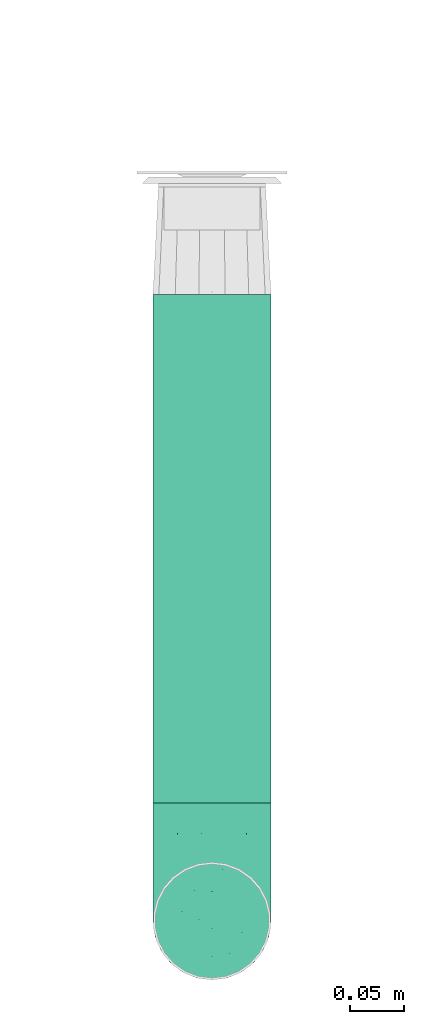
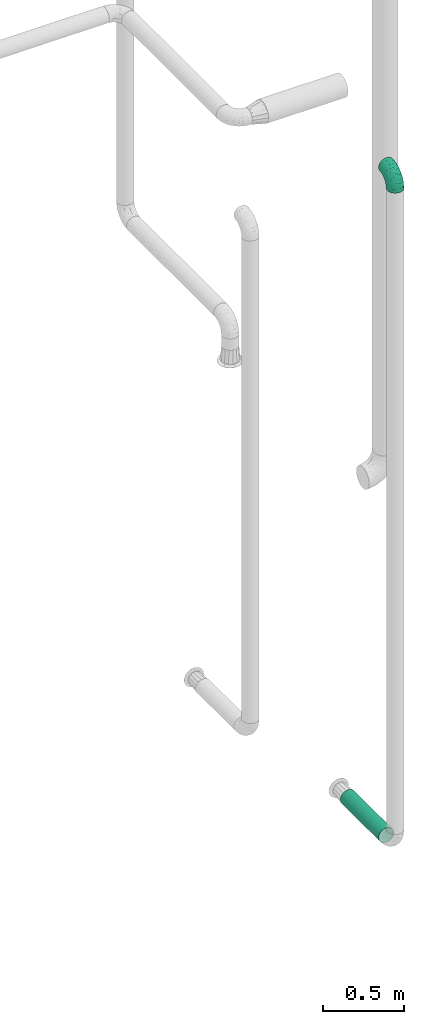
# One storey, part 104 of 115: 1 flow fitting, 1 flow segment.
"""IFC2X3 building model written with IfcOpenShell, lengths in millimetres."""

from ifc_helpers import new_model, entity, si_unit, converted_unit, derived_unit, direction, frame, origin_with_axes, origin_2d_with_axis, place, context, subcontext, project, spatial, hollow_circle, extrude, open_shell, surface_model, source, transform, mapped, material, layer, layer_set, layer_usage, type_object, element, save


model = new_model("IFC2X3")

# Units and contexts
model_context = context("Model", 3, precision=1e-05, world=origin_with_axes(), true_north=direction((0.0, 1.0)))
body_context = subcontext(model_context, "Body", "Model", "MODEL_VIEW")
ifc_project = project(units=[si_unit("AREAUNIT", "SQUARE_METRE"), si_unit("VOLUMEUNIT", "CUBIC_METRE", prefix="DECI"), si_unit("TIMEUNIT", "SECOND"), si_unit("THERMODYNAMICTEMPERATUREUNIT", "DEGREE_CELSIUS"), si_unit("PRESSUREUNIT", "PASCAL"), si_unit("MASSUNIT", "GRAM", prefix="KILO"), si_unit("LENGTHUNIT", "METRE", prefix="MILLI"), si_unit("POWERUNIT", "WATT"), si_unit("ELECTRICCURRENTUNIT", "AMPERE"), si_unit("ELECTRICVOLTAGEUNIT", "VOLT"), derived_unit("VOLUMETRICFLOWRATEUNIT", [(si_unit("VOLUMEUNIT", "CUBIC_METRE", prefix="DECI"), 1), (si_unit("TIMEUNIT", "SECOND"), -1)]), derived_unit("LINEARVELOCITYUNIT", [(si_unit("LENGTHUNIT", "METRE"), 1), (si_unit("TIMEUNIT", "SECOND"), -1)]), derived_unit("MASSDENSITYUNIT", [(si_unit("MASSUNIT", "GRAM", prefix="KILO"), 1), (si_unit("VOLUMEUNIT", "CUBIC_METRE"), -1)]), converted_unit("PLANEANGLEUNIT", "DEGREE", entity("IfcRatioMeasure", 0.01745), si_unit("PLANEANGLEUNIT", "RADIAN"), dimensions=[0, 0, 0, 0, 0, 0, 0])], contexts=[model_context])

# Site, building, storey
site_placement = place(None, origin_with_axes())
site = spatial("IfcSite", under=ifc_project, at=site_placement, CompositionType="ELEMENT")
building_placement = place(site_placement, origin_with_axes())
building = spatial("IfcBuilding", under=site, at=building_placement, Name="mc-building", CompositionType="ELEMENT")
storey_placement = place(building_placement, frame((0.0, 0.0, 2950.0), z_axis=(0.0, 0.0, 1.0), x_axis=(1.0, 0.0, 0.0)))
storey = spatial("IfcBuildingStorey", under=building, at=storey_placement, Name="2. Korrus", CompositionType="ELEMENT", Elevation=2950.0)

# Flow fitting
duct_fitting_type = type_object("IfcDuctFittingType", Name="BU", PredefinedType="BEND")
shared_shape_1 = source(origin_with_axes(), body_context, "Body", "SurfaceModel", [
    surface_model("IfcShellBasedSurfaceModel", [(-110.0, 0.0, -55.0), (-110.0, -14.23505, -53.12592), (-110.0, 14.23505, -53.12592), (-110.0, 53.12592, 14.23505), (-110.0, 27.5, -47.63139), (-110.0, 38.89087, -38.89087), (-110.0, -55.0, 0.0), (-110.0, -53.12592, 14.23505), (-110.0, -38.89087, -38.89087), (-110.0, -27.5, -47.63139), (-110.0, -53.12592, -14.23505), (-110.0, -47.63139, -27.5), (-110.0, -14.23505, 53.12592), (-110.0, 14.23505, 53.12592), (-110.0, 27.5, 47.63139), (-110.0, -47.63139, 27.5), (-110.0, -38.89087, 38.89087), (-110.0, -27.5, 47.63139), (-110.0, 0.0, 55.0), (-110.0, 55.0, 0.0), (-110.0, 53.12592, -14.23505), (-110.0, 47.63139, -27.5), (-110.0, 47.63139, 27.5), (-110.0, 38.89087, 38.89087), (-14.23505, 110.0, -53.12592), (-55.0, 110.0, 0.0), (0.0, 110.0, -55.0), (-27.5, 110.0, -47.63139), (-38.89087, 110.0, -38.89087), (-47.63139, 110.0, -27.5), (38.89087, 110.0, -38.89087), (53.12592, 110.0, 14.23505), (27.5, 110.0, -47.63139), (14.23505, 110.0, -53.12592), (47.63139, 110.0, -27.5), (53.12592, 110.0, -14.23505), (55.0, 110.0, 0.0), (-53.12592, 110.0, -14.23505), (-53.12592, 110.0, 14.23505), (-47.63139, 110.0, 27.5), (-38.89087, 110.0, 38.89087), (-27.5, 110.0, 47.63139), (0.0, 110.0, 55.0), (-14.23505, 110.0, 53.12592), (38.89087, 110.0, 38.89087), (47.63139, 110.0, 27.5), (27.5, 110.0, 47.63139), (14.23505, 110.0, 53.12592), (-64.21732, 48.68956, 43.63444), (-76.6405, 38.18013, 45.55988), (-60.44912, 32.56953, 51.94617), (-76.00813, 5.38378, 55.0), (-90.15553, 11.94394, 54.09138), (-78.5998, 26.77405, 50.81338), (-70.18771, 18.55163, 54.03432), (-75.55424, 54.2118, 32.41257), (-93.27622, 45.77614, 33.48188), (-96.12334, 22.13664, 50.81337), (-21.00813, 45.34362, 55.0), (-18.36258, 70.48427, 54.04484), (-32.04182, 59.64019, 52.24446), (-63.88653, 74.77858, 17.99134), (-74.66383, 63.08407, 19.92123), (-63.60674, 66.07878, 29.97482), (-99.597, 52.72185, 18.52927), (-93.11138, 56.59448, 10.50359), (-98.21577, 57.34403, 0.0), (-53.42855, 92.60092, 21.04759), (-88.54852, 54.8376, 21.04759), (-11.86161, 90.23965, 54.10313), (-5.38378, 76.00813, 55.0), (-57.34403, 98.21577, 0.0), (-56.64619, 93.12774, 10.22088), (-45.34362, 21.00813, 55.0), (-44.60838, 44.60838, 52.13415), (-92.68484, 35.46673, 43.63443), (-22.25266, 95.40765, 50.81337), (-35.97783, 90.61597, 43.63443), (-43.70931, 69.58671, 44.47149), (-27.23711, 77.39884, 50.81337), (-57.2828, 79.3123, 24.9774), (-58.67786, 84.31125, 16.04456), (-82.93277, 60.36161, 12.91784), (-49.88337, 54.51816, 47.224), (-74.57753, 66.83759, 9.55742), (-45.35812, 94.97281, 33.48188), (-59.18663, 88.95241, 0.0), (-51.517, 78.6292, 33.48188), (-65.14788, 80.03077, 0.0), (-56.45322, 62.06476, 39.63545), (-88.95241, 59.18663, 0.0), (-71.10913, 71.10913, 0.0), (-80.03077, 65.14788, 0.0), (-94.9309, 45.36788, -33.48188), (-93.11358, 56.60141, -10.46614), (-99.64997, 52.79499, -18.30015), (-90.20425, 36.08686, -43.63443), (-79.99933, 46.56772, -37.92748), (-76.00813, 5.38378, -55.0), (-72.75364, 19.68651, -53.60527), (-45.34362, 21.00813, -55.0), (-21.91957, 65.12078, -53.85897), (-5.38378, 76.00813, -55.0), (-21.00813, 45.34362, -55.0), (-35.41876, 92.89265, -43.63443), (-91.10309, 11.02766, -54.21832), (-45.77614, 93.27622, -33.48188), (-90.50474, 23.21022, -50.81337), (-70.92854, 33.31794, -49.51754), (-78.52933, 63.35627, -11.73997), (-24.91508, 84.05606, -50.81337), (-88.78941, 54.74452, -21.04759), (-69.59921, 57.34866, -33.48187), (-73.36422, 62.46673, -22.94182), (-63.49062, 67.59111, -28.46929), (-56.59448, 93.11138, -10.50359), (-54.8376, 88.54852, -21.04759), (-54.10679, 75.85581, -32.31867), (-57.75956, 31.09612, -52.80882), (-52.72185, 99.597, -18.52927), (-12.62913, 89.46304, -53.99097), (-34.46825, 66.46123, -50.04329), (-43.9837, 43.9837, -52.42279), (-65.78527, 72.58348, -17.68796), (-70.34468, 43.65295, -44.21951), (-57.47001, 51.99467, -44.91465), (-60.72547, 82.29174, -12.88567), (-42.34915, 74.24548, -43.63444), (-57.25194, 63.5016, -38.08211), (-80.95344, 53.56991, -29.32027), (-52.32891, 4.55257, -54.0482), (32.52942, 47.13398, -30.48571), (14.88266, 20.92917, -33.7947), (14.95561, 36.05775, -42.26543), (30.24048, 70.09027, -41.7461), (19.3559, 65.35825, -48.00507), (-70.35075, -46.44478, -19.5952), (-47.13398, -32.52942, -30.48571), (-28.49299, -30.5778, -16.4009), (-4.55257, 52.32891, -54.0482), (-22.4954, 22.4954, -53.25347), (-75.47368, -11.22546, -52.60718), (-81.32209, -51.5606, -9.98467), (-80.81763, -41.84862, -32.14655), (-70.09027, -30.24048, -41.7461), (-36.05774, -14.95561, -42.26543), (-9.15831, -10.852, -27.8997), (-65.35825, -19.3559, -48.00507), (11.22546, 75.47368, -52.60718), (3.94376, 43.9333, -50.53315), (-13.39742, 13.39743, -48.13058), (-43.9333, -3.94376, -50.53315), (49.37776, 67.29486, 0.0), (41.8609, 47.82256, -9.92641), (50.20582, 74.51695, -9.9731), (18.93131, 11.7156, -17.56239), (-27.5, -32.89419, 0.0), (-1.23348, -12.25375, -12.18106), (41.84862, 80.81763, -32.14655), (35.70604, 41.31408, -20.38235), (46.44478, 70.35075, -19.5952), (32.89419, 27.5, 0.0), (6.67262, -6.67262, 0.0), (-67.29486, -49.37776, 0.0), (-50.36265, -42.95545, -9.51562), (-5.47251, 5.47251, -39.92906), (-70.35075, -46.44478, 19.5952), (-74.51695, -50.20582, 9.9731), (-41.31407, -35.70604, 20.38235), (-47.13398, -32.52942, 30.48571), (-80.81763, -41.84862, 32.14655), (-4.55257, 52.32891, 54.0482), (11.22546, 75.47368, 52.60718), (-43.9333, -3.94376, 50.53315), (-65.35825, -19.3559, 48.00507), (-36.05774, -14.95561, 42.26543), (-70.09027, -30.24048, 41.7461), (-11.7156, -18.93131, 17.56239), (30.5778, 28.49299, 16.4009), (12.25375, 1.23348, 12.18106), (51.5606, 81.32209, 9.98467), (42.95545, 50.36265, 9.51562), (-75.47368, -11.22546, 52.60718), (-52.32891, 4.55257, 54.0482), (3.94376, 43.9333, 50.53315), (-22.4954, 22.4954, 53.25347), (-13.39742, 13.39743, 48.13058), (10.852, 9.15831, 27.8997), (-20.92916, -14.88266, 33.79469), (-47.82256, -41.8609, 9.92641), (32.52942, 47.13398, 30.48571), (46.44478, 70.35075, 19.5952), (41.84862, 80.81763, 32.14655), (30.24048, 70.09027, 41.7461), (19.3559, 65.35825, 48.00507), (14.95561, 36.05775, 42.26543), (-5.47251, 5.47251, 39.92906)], [open_shell([[[0, 1, 2]], [[2, 3, 4]], [[4, 3, 5]], [[2, 6, 7]], [[8, 6, 9]], [[1, 9, 6]], [[10, 6, 11]], [[8, 11, 6]], [[6, 2, 1]], [[12, 13, 14]], [[15, 2, 7]], [[16, 17, 2]], [[2, 17, 12]], [[12, 18, 13]], [[19, 20, 3]], [[5, 3, 21]], [[20, 21, 3]], [[22, 3, 2]], [[23, 22, 2]], [[12, 14, 2]], [[2, 14, 23]], [[15, 16, 2]], [[24, 25, 26]], [[27, 25, 24]], [[25, 28, 29]], [[28, 25, 27]], [[30, 26, 31]], [[26, 30, 32]], [[32, 33, 26]], [[34, 31, 35]], [[31, 34, 30]], [[35, 31, 36]], [[29, 37, 25]], [[38, 39, 26]], [[39, 40, 26]], [[41, 42, 40]], [[42, 26, 40]], [[42, 41, 43]], [[26, 44, 45]], [[31, 26, 45]], [[26, 46, 44]], [[47, 46, 26]], [[42, 47, 26]], [[25, 38, 26]], [[48, 49, 50]], [[18, 51, 52]], [[53, 54, 50]], [[55, 56, 49]], [[56, 22, 23]], [[13, 57, 14]], [[58, 59, 60]], [[61, 62, 63]], [[3, 64, 65]], [[53, 52, 54]], [[3, 65, 66]], [[67, 39, 38]], [[56, 68, 64]], [[65, 64, 68]], [[69, 59, 70]], [[38, 71, 72]], [[73, 58, 74]], [[75, 49, 56]], [[76, 69, 43]], [[53, 57, 52]], [[77, 78, 79]], [[41, 76, 43]], [[43, 69, 42]], [[55, 68, 56]], [[23, 14, 75]], [[76, 77, 79]], [[80, 67, 81]], [[62, 82, 68]], [[60, 78, 83]], [[62, 84, 82]], [[85, 77, 40]], [[81, 67, 72]], [[86, 72, 71]], [[87, 85, 67]], [[61, 81, 88]], [[77, 41, 40]], [[78, 77, 87]], [[23, 75, 56]], [[83, 89, 48]], [[85, 40, 39]], [[62, 68, 55]], [[89, 87, 63]], [[83, 48, 50]], [[57, 75, 14]], [[49, 75, 53]], [[67, 85, 39]], [[87, 77, 85]], [[63, 62, 55]], [[89, 55, 48]], [[80, 63, 87]], [[66, 65, 90]], [[66, 19, 3]], [[84, 91, 92]], [[92, 90, 82]], [[65, 82, 90]], [[61, 84, 62]], [[92, 82, 84]], [[68, 82, 65]], [[3, 22, 64]], [[56, 64, 22]], [[38, 25, 71]], [[81, 72, 86]], [[38, 72, 67]], [[91, 61, 88]], [[80, 81, 61]], [[63, 80, 61]], [[67, 80, 87]], [[77, 76, 41]], [[79, 59, 69]], [[79, 69, 76]], [[42, 69, 70]], [[60, 59, 79]], [[58, 70, 59]], [[78, 60, 79]], [[58, 60, 74]], [[52, 57, 13]], [[75, 57, 53]], [[18, 52, 13]], [[52, 51, 54]], [[51, 73, 54]], [[50, 73, 74]], [[73, 50, 54]], [[50, 74, 83]], [[60, 83, 74]], [[89, 83, 78]], [[87, 89, 78]], [[55, 89, 63]], [[50, 49, 53]], [[55, 49, 48]], [[81, 86, 88]], [[91, 84, 61]], [[5, 21, 93]], [[90, 94, 66]], [[20, 94, 95]], [[96, 93, 97]], [[98, 99, 100]], [[96, 4, 5]], [[101, 102, 103]], [[28, 27, 104]], [[2, 105, 0]], [[104, 106, 28]], [[99, 105, 107]], [[108, 107, 96]], [[90, 109, 94]], [[107, 2, 4]], [[20, 66, 94]], [[27, 24, 110]], [[109, 111, 94]], [[112, 113, 114]], [[37, 115, 71]], [[116, 106, 117]], [[99, 118, 100]], [[116, 115, 119]], [[37, 119, 115]], [[24, 120, 110]], [[121, 110, 101]], [[119, 106, 116]], [[101, 110, 120]], [[122, 103, 100]], [[117, 123, 116]], [[124, 125, 108]], [[115, 116, 126]], [[106, 29, 28]], [[26, 102, 120]], [[127, 104, 110]], [[97, 124, 96]], [[125, 122, 118]], [[128, 127, 125]], [[96, 5, 93]], [[115, 126, 86]], [[117, 106, 127]], [[111, 113, 129]], [[95, 93, 21]], [[97, 129, 112]], [[110, 104, 27]], [[106, 104, 127]], [[96, 107, 4]], [[99, 107, 108]], [[99, 108, 118]], [[105, 99, 98]], [[112, 114, 128]], [[121, 125, 127]], [[20, 19, 66]], [[109, 90, 92]], [[94, 111, 95]], [[91, 123, 109]], [[129, 113, 112]], [[93, 95, 111]], [[21, 20, 95]], [[71, 115, 86]], [[71, 25, 37]], [[123, 91, 88]], [[126, 116, 123]], [[123, 88, 126]], [[86, 126, 88]], [[37, 29, 119]], [[106, 119, 29]], [[129, 93, 111]], [[124, 112, 125]], [[0, 105, 98]], [[107, 105, 2]], [[125, 118, 108]], [[100, 118, 122]], [[93, 129, 97]], [[113, 111, 109]], [[109, 123, 113]], [[114, 123, 117]], [[123, 114, 113]], [[128, 114, 117]], [[127, 128, 117]], [[112, 128, 125]], [[103, 122, 101]], [[110, 121, 127]], [[101, 122, 121]], [[125, 121, 122]], [[26, 120, 24]], [[101, 120, 102]], [[96, 124, 108]], [[92, 91, 109]], [[112, 124, 97]], [[100, 130, 98]], [[131, 132, 133]], [[32, 134, 135]], [[136, 137, 138]], [[139, 140, 103]], [[98, 141, 0]], [[142, 10, 136]], [[143, 144, 137]], [[6, 10, 142]], [[137, 145, 146]], [[144, 147, 145]], [[143, 136, 11]], [[11, 136, 10]], [[8, 143, 11]], [[148, 149, 139]], [[8, 9, 144]], [[9, 1, 147]], [[130, 141, 98]], [[103, 140, 100]], [[148, 135, 149]], [[150, 151, 140]], [[152, 153, 154]], [[130, 140, 151]], [[148, 26, 33]], [[147, 1, 141]], [[155, 146, 132]], [[156, 138, 157]], [[134, 30, 158]], [[150, 140, 149]], [[158, 30, 34]], [[30, 134, 32]], [[153, 159, 160]], [[131, 160, 159]], [[144, 145, 137]], [[36, 152, 154]], [[146, 138, 137]], [[155, 161, 162]], [[158, 160, 131]], [[133, 149, 135]], [[156, 163, 164]], [[163, 142, 164]], [[139, 103, 102]], [[153, 152, 161]], [[34, 35, 160]], [[162, 157, 155]], [[132, 165, 133]], [[157, 146, 155]], [[140, 130, 100]], [[141, 130, 151]], [[141, 151, 147]], [[141, 1, 0]], [[102, 26, 148]], [[140, 139, 149]], [[102, 148, 139]], [[135, 33, 32]], [[151, 150, 145]], [[9, 147, 144]], [[151, 145, 147]], [[145, 165, 146]], [[135, 148, 33]], [[133, 135, 134]], [[131, 133, 134]], [[133, 165, 150]], [[133, 150, 149]], [[145, 150, 165]], [[132, 131, 159]], [[146, 165, 132]], [[160, 158, 34]], [[134, 158, 131]], [[144, 143, 8]], [[136, 143, 137]], [[155, 153, 161]], [[154, 153, 160]], [[153, 155, 159]], [[132, 159, 155]], [[160, 35, 154]], [[36, 154, 35]], [[164, 136, 138]], [[6, 142, 163]], [[136, 164, 142]], [[156, 164, 138]], [[156, 157, 162]], [[146, 157, 138]], [[15, 7, 166]], [[6, 163, 167]], [[168, 169, 166]], [[166, 169, 170]], [[171, 172, 70]], [[173, 174, 175]], [[17, 176, 174]], [[177, 156, 162]], [[176, 16, 170]], [[170, 16, 15]], [[161, 178, 179]], [[152, 180, 181]], [[182, 173, 183]], [[18, 12, 182]], [[184, 185, 186]], [[183, 185, 73]], [[183, 73, 51]], [[177, 187, 188]], [[189, 168, 166]], [[187, 178, 190]], [[16, 176, 17]], [[161, 152, 181]], [[45, 191, 31]], [[45, 44, 192]], [[192, 191, 45]], [[180, 36, 31]], [[193, 194, 195]], [[46, 47, 194]], [[193, 195, 190]], [[193, 44, 46]], [[172, 42, 70]], [[185, 58, 73]], [[189, 163, 156]], [[163, 189, 167]], [[70, 58, 171]], [[184, 171, 185]], [[169, 188, 175]], [[180, 31, 191]], [[192, 193, 190]], [[191, 190, 178]], [[182, 174, 173]], [[194, 47, 172]], [[190, 195, 187]], [[186, 185, 173]], [[162, 179, 177]], [[188, 196, 175]], [[179, 187, 177]], [[185, 171, 58]], [[172, 171, 184]], [[172, 184, 194]], [[172, 47, 42]], [[51, 18, 182]], [[185, 183, 173]], [[51, 182, 183]], [[174, 12, 17]], [[184, 186, 195]], [[46, 194, 193]], [[184, 195, 194]], [[195, 196, 187]], [[174, 182, 12]], [[175, 174, 176]], [[169, 175, 176]], [[175, 196, 186]], [[175, 186, 173]], [[195, 186, 196]], [[188, 169, 168]], [[187, 196, 188]], [[166, 170, 15]], [[176, 170, 169]], [[193, 192, 44]], [[191, 192, 190]], [[177, 189, 156]], [[167, 189, 166]], [[189, 177, 168]], [[188, 168, 177]], [[166, 7, 167]], [[6, 167, 7]], [[181, 191, 178]], [[36, 180, 152]], [[191, 181, 180]], [[161, 181, 178]], [[161, 179, 162]], [[187, 179, 178]]])]),
])
flow_fitting_placement = place(storey_placement, frame((34787.74688, -687.64676, 6165.0), z_axis=(-1.0, 0.0, 0.0), x_axis=(0.0, 0.0, 1.0)))
element("IfcFlowFitting", 1, at=flow_fitting_placement, inside=storey, type_object=duct_fitting_type, Name="BU", context=body_context, shape_type="MappedRepresentation", body=[
    mapped(shared_shape_1, transform((0.0, 0.0, 0.0), scale=1.0)),
])

# Flow segment
ifc_material = material(Name="FZ1")
ifc_layer = layer(ifc_material, 0.0)
ifc_layer_set = layer_set([ifc_layer], Name="FZ1")
ifc_layer_usage = layer_usage(ifc_layer_set, "AXIS1", "POSITIVE", 0.0)
duct_segment_type = type_object("IfcDuctSegmentType", PredefinedType="RIGIDSEGMENT")
shared_shape_2 = source(origin_with_axes(), body_context, "Body", "SweptSolid", [
    extrude(hollow_circle(Radius=55.0, WallThickness=2.0, at=origin_2d_with_axis()), frame((0.0, 0.0, 0.0), z_axis=(1.0, 0.0, 0.0), x_axis=(0.0, 1.0, 0.0)), (0.0, 0.0, 1.0), 474.5),
])
flow_segment_placement = place(storey_placement, frame((34787.74688, -103.1, 1100.0), z_axis=(0.0, 0.0, 1.0), x_axis=(0.0, -1.0, 0.0)))
element("IfcFlowSegment", 2, at=flow_segment_placement, inside=storey, type_object=duct_segment_type, material=ifc_layer_usage, context=body_context, shape_type="MappedRepresentation", body=[
    mapped(shared_shape_2, transform((0.0, 0.0, 0.0), scale=1.0)),
])

save(model, "model.ifc")
